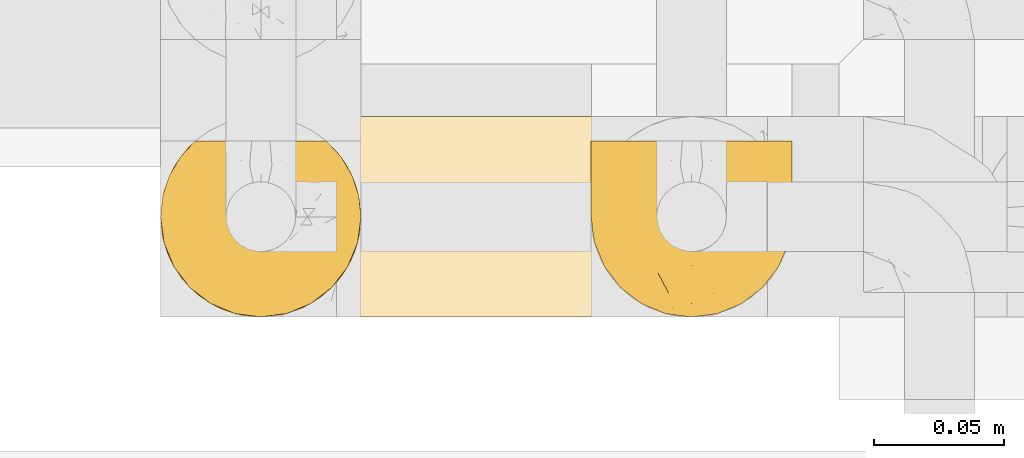
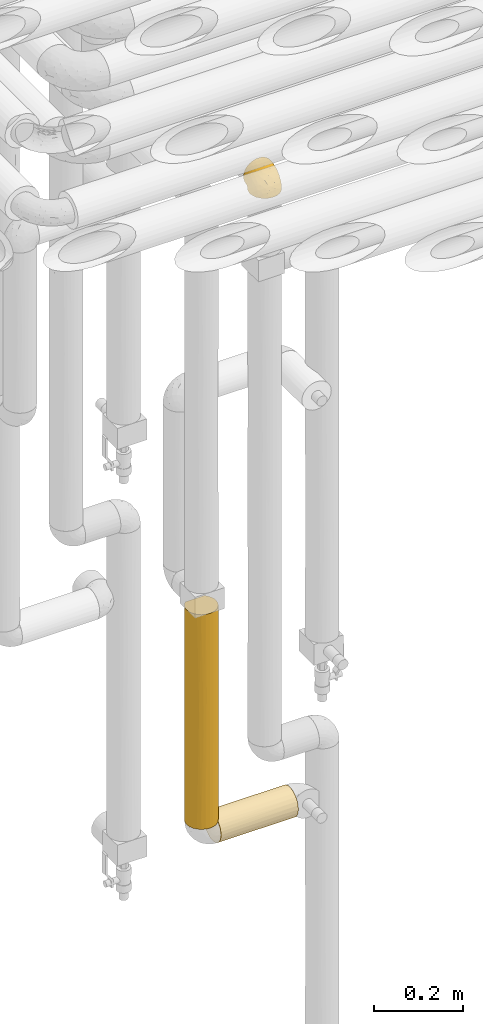
# One storey, part 281 of 827: 3 coverings.
"""IFC2X3 building model written with IfcOpenShell, lengths in millimetres."""

from ifc_helpers import new_model, entity, si_unit, converted_unit, derived_unit, direction, frame, origin, place, context, subcontext, project, spatial, faceted_brep, element, save


model = new_model("IFC2X3")

# Units and contexts
model_context = context("Model", 3, precision=0.01, world=origin(), true_north=direction((6.12303176911189e-17, 1.0)))
body_context = subcontext(model_context, "Body", "Model", "MODEL_VIEW")
ifc_project = project(units=[si_unit("LENGTHUNIT", "METRE", prefix="MILLI"), si_unit("AREAUNIT", "SQUARE_METRE"), si_unit("VOLUMEUNIT", "CUBIC_METRE"), converted_unit("PLANEANGLEUNIT", "DEGREE", entity("IfcRatioMeasure", 0.0174532925199433), si_unit("PLANEANGLEUNIT", "RADIAN"), dimensions=[0, 0, 0, 0, 0, 0, 0]), si_unit("MASSUNIT", "GRAM", prefix="KILO"), derived_unit("MASSDENSITYUNIT", [(si_unit("MASSUNIT", "GRAM", prefix="KILO"), 1), (si_unit("LENGTHUNIT", "METRE"), -3)]), derived_unit("MOMENTOFINERTIAUNIT", [(si_unit("LENGTHUNIT", "METRE"), 4)]), si_unit("TIMEUNIT", "SECOND"), si_unit("FREQUENCYUNIT", "HERTZ"), si_unit("THERMODYNAMICTEMPERATUREUNIT", "DEGREE_CELSIUS"), derived_unit("THERMALTRANSMITTANCEUNIT", [(si_unit("MASSUNIT", "GRAM", prefix="KILO"), 1), (si_unit("THERMODYNAMICTEMPERATUREUNIT", "KELVIN"), -1), (si_unit("TIMEUNIT", "SECOND"), -3)]), derived_unit("VOLUMETRICFLOWRATEUNIT", [(si_unit("LENGTHUNIT", "METRE"), 3), (si_unit("TIMEUNIT", "SECOND"), -1)]), derived_unit("MASSFLOWRATEUNIT", [(si_unit("MASSUNIT", "GRAM", prefix="KILO"), 1), (si_unit("TIMEUNIT", "SECOND"), -1)]), derived_unit("ROTATIONALFREQUENCYUNIT", [(si_unit("TIMEUNIT", "SECOND"), -1)]), si_unit("ELECTRICCURRENTUNIT", "AMPERE"), si_unit("ELECTRICVOLTAGEUNIT", "VOLT"), si_unit("POWERUNIT", "WATT"), si_unit("FORCEUNIT", "NEWTON", prefix="KILO"), si_unit("ILLUMINANCEUNIT", "LUX"), si_unit("LUMINOUSFLUXUNIT", "LUMEN"), si_unit("LUMINOUSINTENSITYUNIT", "CANDELA"), derived_unit("USERDEFINED", [(si_unit("MASSUNIT", "GRAM", prefix="KILO"), -1), (si_unit("LENGTHUNIT", "METRE"), -2), (si_unit("TIMEUNIT", "SECOND"), 3), (si_unit("LUMINOUSFLUXUNIT", "LUMEN"), 1)]), derived_unit("LINEARVELOCITYUNIT", [(si_unit("LENGTHUNIT", "METRE"), 1), (si_unit("TIMEUNIT", "SECOND"), -1)]), si_unit("PRESSUREUNIT", "PASCAL"), derived_unit("USERDEFINED", [(si_unit("LENGTHUNIT", "METRE"), -2), (si_unit("MASSUNIT", "GRAM", prefix="KILO"), 1), (si_unit("TIMEUNIT", "SECOND"), -2)]), derived_unit("LINEARFORCEUNIT", [(si_unit("MASSUNIT", "GRAM", prefix="KILO"), 1), (si_unit("LENGTHUNIT", "METRE"), 1), (si_unit("TIMEUNIT", "SECOND"), -2), (si_unit("LENGTHUNIT", "METRE"), -1)]), derived_unit("PLANARFORCEUNIT", [(si_unit("MASSUNIT", "GRAM", prefix="KILO"), 1), (si_unit("LENGTHUNIT", "METRE"), 1), (si_unit("TIMEUNIT", "SECOND"), -2), (si_unit("LENGTHUNIT", "METRE"), -2)])], contexts=[model_context])

# Site, building, storey
site_placement = place(None, origin())
site = spatial("IfcSite", under=ifc_project, at=site_placement, CompositionType="ELEMENT")
building_placement = place(site_placement, origin())
building = spatial("IfcBuilding", under=site, at=building_placement, CompositionType="ELEMENT")
storey_placement = place(building_placement, frame((0.0, 0.0, 28200.0)))
storey = spatial("IfcBuildingStorey", under=building, at=storey_placement, Name="08", CompositionType="ELEMENT", Elevation=28200.0)

# Coverings
covering_1_placement = place(storey_placement, frame((34952.84, 14884.87, 2769.3)))
element("IfcCovering", 1, at=covering_1_placement, inside=storey, Name=":ADSK_", ObjectType=":ADSK_", PredefinedType="INSULATION", context=body_context, shape_type="Brep", body=[
    faceted_brep([(5.41, 69.15, 47.38), (9.99, 69.15, 54.67), (16.08, 69.15, 60.76), (23.37, 69.15, 65.34), (31.49, 69.15, 68.18), (40.05, 69.15, 69.15), (48.61, 69.15, 68.18), (56.73, 69.15, 65.33), (64.02, 69.15, 60.75), (70.11, 69.15, 54.66), (74.69, 69.15, 47.37), (77.53, 69.15, 39.25), (78.5, 69.15, 30.7), (77.63, 69.15, 22.59), (75.08, 69.15, 14.86), (70.97, 69.15, 7.84), (65.47, 69.15, 1.85), (63.27, 69.15, 1.85), (61.53, 69.15, 1.85), (59.57, 69.15, 1.85), (57.6, 69.15, 1.85), (55.63, 69.15, 1.85), (53.67, 69.15, 1.85), (51.7, 69.15, 1.85), (49.73, 69.15, 1.85), (47.54, 69.15, 1.85), (45.34, 69.15, 1.85), (43.15, 69.15, 1.85), (40.96, 69.15, 1.85), (38.76, 69.15, 1.85), (36.57, 69.15, 1.85), (34.37, 69.15, 1.85), (32.18, 69.15, 1.85), (29.98, 69.15, 1.85), (27.79, 69.15, 1.85), (25.6, 69.15, 1.85), (23.4, 69.15, 1.85), (21.21, 69.15, 1.85), (19.01, 69.15, 1.85), (16.82, 69.15, 1.85), (14.62, 69.15, 1.85), (9.12, 69.15, 7.85), (5.0, 69.15, 14.88), (2.46, 69.15, 22.61), (1.6, 69.15, 30.7), (2.56, 69.15, 39.26), (65.47, 68.89, 1.6), (70.97, 62.89, 1.6), (75.09, 55.87, 1.6), (77.63, 48.14, 1.6), (78.5, 40.05, 1.6), (77.19, 30.09, 1.6), (73.34, 20.82, 1.6), (67.23, 12.86, 1.6), (59.27, 6.75, 1.6), (50.0, 2.91, 1.6), (40.05, 1.6, 1.6), (30.09, 2.91, 1.6), (20.82, 6.75, 1.6), (12.86, 12.86, 1.6), (6.75, 20.82, 1.6), (2.91, 30.09, 1.6), (1.6, 40.05, 1.6), (2.46, 48.14, 1.6), (5.0, 55.87, 1.6), (9.12, 62.89, 1.6), (14.62, 68.89, 1.6), (16.82, 68.89, 1.6), (17.8, 68.89, 1.6), (19.39, 68.89, 1.6), (20.98, 68.89, 1.6), (22.57, 68.89, 1.6), (24.16, 68.89, 1.6), (25.75, 68.89, 1.6), (27.33, 68.89, 1.6), (28.92, 68.89, 1.6), (30.51, 68.89, 1.6), (32.1, 68.89, 1.6), (33.69, 68.89, 1.6), (35.28, 68.89, 1.6), (36.87, 68.89, 1.6), (38.46, 68.89, 1.6), (40.05, 68.89, 1.6), (41.63, 68.89, 1.6), (43.22, 68.89, 1.6), (44.81, 68.89, 1.6), (46.4, 68.89, 1.6), (47.99, 68.89, 1.6), (49.58, 68.89, 1.6), (51.17, 68.89, 1.6), (52.76, 68.89, 1.6), (54.72, 68.89, 1.6), (56.69, 68.89, 1.6), (58.88, 68.89, 1.6), (61.08, 68.89, 1.6), (63.27, 68.89, 1.6), (37.77, 68.97, 1.78), (36.07, 68.96, 1.77), (32.96, 68.97, 1.78), (31.36, 68.97, 1.77), (56.52, 68.98, 1.79), (54.96, 68.97, 1.78), (18.75, 68.96, 1.76), (58.07, 68.96, 1.77), (50.37, 68.96, 1.77), (23.36, 68.96, 1.76), (24.95, 68.96, 1.77), (42.43, 68.96, 1.77), (15.97, 69.0, 1.8), (51.96, 68.96, 1.76), (53.47, 68.96, 1.77), (48.63, 68.97, 1.78), (63.93, 68.96, 1.77), (40.93, 68.96, 1.77), (29.72, 68.96, 1.76), (62.4, 68.97, 1.77), (60.92, 68.97, 1.78), (17.31, 68.97, 1.77), (21.74, 68.96, 1.77), (34.56, 68.96, 1.77), (20.18, 68.97, 1.78), (14.62, 68.97, 1.77), (14.62, 69.02, 1.8), (14.62, 69.08, 1.82), (65.47, 68.97, 1.77), (65.47, 68.94, 1.72), (65.47, 68.92, 1.66), (59.5, 68.96, 1.76), (47.1, 68.96, 1.77), (45.61, 68.95, 1.76), (28.18, 68.96, 1.77), (14.62, 68.92, 1.66), (14.62, 68.94, 1.72), (26.61, 68.98, 1.78), (65.47, 69.08, 1.82), (65.47, 69.02, 1.8), (39.32, 68.96, 1.77), (44.12, 68.97, 1.78), (72.26, 61.33, 3.72), (76.57, 53.1, 7.41), (71.77, 63.33, 6.13), (77.9, 55.53, 19.34), (76.56, 63.33, 17.64), (78.5, 54.6, 26.8), (78.5, 41.99, 8.87), (75.52, 57.07, 9.2), (76.13, 57.95, 12.79), (77.81, 51.56, 14.62), (78.5, 41.58, 7.34), (72.4, 61.7, 5.33), (71.77, 65.0, 7.7), (72.25, 67.02, 9.41), (78.5, 61.87, 28.75), (78.5, 49.27, 21.47), (78.5, 43.94, 16.15), (75.75, 61.21, 14.14), (78.5, 63.4, 29.16), (50.46, 33.11, 57.02), (52.75, 52.82, 64.92), (40.05, 43.3, 64.0), (77.7, 33.73, 11.92), (77.66, 36.52, 19.16), (71.02, 24.87, 28.65), (63.45, 14.17, 24.62), (70.55, 18.43, 15.19), (75.57, 28.67, 18.36), (75.57, 26.0, 9.2), (72.61, 49.25, 46.98), (72.61, 59.72, 50.24), (67.24, 55.1, 56.1), (77.74, 44.72, 28.97), (57.43, 34.15, 54.46), (47.19, 5.25, 21.34), (54.76, 6.75, 18.4), (40.05, 55.54, 66.44), (63.45, 10.47, 12.07), (60.1, 25.49, 45.49), (63.72, 35.53, 50.57), (76.83, 48.22, 36.04), (76.34, 58.71, 42.07), (60.51, 57.42, 62.12), (72.59, 34.84, 37.37), (76.05, 36.87, 29.39), (66.15, 45.01, 53.59), (60.51, 44.4, 58.06), (51.88, 23.96, 49.27), (55.34, 11.2, 29.63), (48.67, 10.56, 33.21), (53.89, 16.81, 40.1), (46.73, 17.38, 44.08), (40.05, 21.38, 49.36), (40.05, 32.34, 56.68), (40.05, 4.3, 15.2), (63.95, 20.65, 35.57), (67.24, 29.66, 41.7), (69.62, 39.6, 46.4), (73.6, 42.55, 41.41), (40.05, 6.74, 27.45), (40.05, 14.06, 38.4), (4.52, 26.84, 12.99), (32.72, 5.28, 21.33), (27.18, 18.52, 42.89), (29.63, 33.13, 57.04), (12.86, 55.1, 56.11), (19.59, 57.43, 62.13), (9.54, 20.72, 21.89), (16.64, 11.46, 16.62), (17.48, 17.69, 32.9), (7.49, 49.26, 46.99), (7.49, 59.73, 50.25), (3.75, 58.71, 42.08), (20.75, 29.72, 49.91), (2.33, 35.35, 15.6), (1.6, 43.94, 16.15), (1.6, 41.99, 8.87), (1.6, 63.4, 29.16), (26.94, 4.93, 13.16), (9.54, 17.46, 10.83), (31.21, 10.94, 33.8), (25.33, 8.92, 25.02), (27.35, 52.83, 64.92), (8.17, 29.34, 32.83), (4.3, 30.26, 20.56), (19.59, 44.4, 58.07), (2.23, 39.06, 21.46), (2.45, 43.06, 28.1), (1.6, 54.6, 26.8), (1.6, 49.27, 21.47), (12.86, 42.69, 51.29), (3.27, 48.2, 36.04), (1.6, 61.87, 28.75), (2.29, 33.44, 8.45), (12.86, 29.67, 41.73), (6.89, 38.5, 39.27), (12.43, 23.35, 33.56), (4.1, 34.97, 27.29), (3.53, 53.1, 7.41), (6.88, 59.68, 3.51), (8.16, 62.19, 4.68), (9.02, 64.11, 5.52), (5.0, 57.97, 8.75), (3.96, 57.95, 12.79), (3.52, 63.33, 17.65), (2.4, 51.77, 13.9), (7.83, 67.02, 9.42), (8.32, 64.98, 7.68), (2.19, 55.53, 19.33), (4.34, 61.22, 14.13)], [[[0, 1, 2, 3, 4, 5, 6, 7, 8, 9, 10, 11, 12, 13, 14, 15, 16, 17, 18, 19, 20, 21, 22, 23, 24, 25, 26, 27, 28, 29, 30, 31, 32, 33, 34, 35, 36, 37, 38, 39, 40, 41, 42, 43, 44, 45]], [[46, 47, 48, 49, 50, 51, 52, 53, 54, 55, 56, 57, 58, 59, 60, 61, 62, 63, 64, 65, 66, 67, 68, 69, 70, 71, 72, 73, 74, 75, 76, 77, 78, 79, 80, 81, 82, 83, 84, 85, 86, 87, 88, 89, 90, 91, 92, 93, 94, 95]], [[96, 97, 30]], [[98, 77, 99]], [[100, 101, 21]], [[69, 68, 102]], [[20, 19, 103]], [[24, 23, 104]], [[20, 103, 100]], [[72, 105, 106]], [[84, 83, 107]], [[89, 88, 104]], [[108, 67, 66]], [[109, 110, 90]], [[111, 25, 24]], [[112, 17, 16]], [[82, 113, 83]], [[109, 23, 22]], [[114, 76, 75]], [[105, 36, 106]], [[104, 111, 24]], [[18, 115, 116]], [[97, 96, 80]], [[67, 108, 117]], [[105, 71, 118]], [[31, 97, 119]], [[102, 120, 69]], [[108, 121, 122, 123, 40]], [[112, 95, 115]], [[17, 115, 18]], [[94, 116, 115]], [[117, 68, 67]], [[38, 117, 39]], [[112, 124, 125, 126, 46]], [[17, 112, 115]], [[70, 120, 118]], [[39, 117, 108]], [[120, 38, 37]], [[120, 37, 118]], [[120, 70, 69]], [[116, 94, 127]], [[128, 86, 129]], [[117, 38, 102]], [[74, 130, 75]], [[99, 33, 32]], [[115, 95, 94]], [[39, 108, 40]], [[108, 66, 131, 132, 121]], [[105, 72, 71]], [[118, 37, 36]], [[71, 70, 118]], [[35, 106, 36]], [[36, 105, 118]], [[35, 133, 106]], [[74, 73, 133]], [[106, 133, 73]], [[99, 114, 33]], [[133, 35, 34]], [[73, 72, 106]], [[95, 112, 46]], [[112, 16, 134, 135, 124]], [[130, 114, 75]], [[99, 76, 114]], [[114, 130, 33]], [[34, 33, 130]], [[78, 77, 98]], [[98, 119, 78]], [[130, 133, 34]], [[133, 130, 74]], [[79, 97, 80]], [[98, 99, 32]], [[98, 32, 31]], [[77, 76, 99]], [[97, 79, 119]], [[136, 96, 29]], [[30, 97, 31]], [[136, 29, 28]], [[81, 80, 96]], [[29, 96, 30]], [[31, 119, 98]], [[119, 79, 78]], [[96, 136, 81]], [[82, 81, 136]], [[113, 107, 83]], [[84, 107, 137]], [[107, 27, 137]], [[113, 28, 107]], [[27, 107, 28]], [[85, 84, 137]], [[137, 27, 26]], [[113, 136, 28]], [[136, 113, 82]], [[109, 89, 104]], [[86, 85, 129]], [[89, 109, 90]], [[111, 87, 128]], [[26, 129, 137]], [[88, 111, 104]], [[25, 111, 128]], [[22, 110, 109]], [[23, 109, 104]], [[110, 91, 90]], [[100, 92, 101]], [[110, 22, 101]], [[91, 110, 101]], [[116, 19, 18]], [[111, 88, 87]], [[127, 103, 19]], [[25, 128, 26]], [[86, 128, 87]], [[128, 129, 26]], [[137, 129, 85]], [[120, 102, 38]], [[117, 102, 68]], [[91, 101, 92]], [[21, 101, 22]], [[93, 92, 103]], [[100, 21, 20]], [[100, 103, 92]], [[127, 93, 103]], [[93, 127, 94]], [[116, 127, 19]], [[126, 138, 47]], [[48, 138, 139]], [[140, 125, 124]], [[141, 142, 143]], [[144, 49, 139]], [[145, 140, 146]], [[48, 139, 49]], [[139, 145, 147]], [[49, 144, 148, 50]], [[126, 125, 149]], [[14, 13, 142]], [[150, 146, 140]], [[149, 140, 145]], [[151, 150, 135]], [[151, 14, 142]], [[16, 15, 134]], [[13, 152, 142]], [[124, 150, 140]], [[141, 143, 153]], [[14, 151, 15]], [[15, 151, 134]], [[47, 46, 126]], [[139, 154, 144]], [[138, 48, 47]], [[125, 140, 149]], [[135, 134, 151]], [[146, 155, 141]], [[145, 146, 147]], [[149, 139, 138]], [[147, 153, 154]], [[147, 146, 141]], [[139, 147, 154]], [[139, 149, 145]], [[149, 138, 126]], [[147, 141, 153]], [[146, 150, 155]], [[151, 155, 150]], [[142, 141, 155]], [[13, 12, 156, 152]], [[152, 143, 142]], [[151, 142, 155]], [[150, 124, 135]], [[157, 158, 159]], [[160, 154, 161]], [[162, 163, 164]], [[165, 166, 160]], [[167, 168, 169]], [[153, 170, 161]], [[156, 12, 11]], [[158, 157, 171]], [[172, 55, 173]], [[158, 6, 174]], [[175, 54, 53]], [[52, 166, 164]], [[52, 164, 53]], [[54, 175, 173]], [[166, 52, 51]], [[176, 177, 171]], [[178, 143, 179]], [[156, 11, 179]], [[8, 7, 180]], [[169, 9, 8]], [[179, 143, 152, 156]], [[179, 11, 10]], [[168, 179, 10]], [[181, 162, 182]], [[179, 167, 178]], [[183, 184, 177]], [[183, 169, 184]], [[176, 171, 185]], [[172, 186, 187]], [[158, 7, 6]], [[159, 158, 174]], [[184, 180, 158]], [[54, 173, 55]], [[180, 169, 8]], [[188, 189, 187]], [[9, 168, 10]], [[186, 188, 187]], [[190, 157, 159, 191]], [[55, 172, 192]], [[176, 193, 194]], [[161, 170, 182]], [[162, 164, 165]], [[175, 164, 163]], [[51, 50, 148]], [[167, 195, 196]], [[178, 182, 170]], [[6, 5, 174]], [[158, 180, 7]], [[169, 180, 184]], [[169, 168, 9]], [[179, 168, 167]], [[182, 162, 165]], [[162, 194, 193]], [[161, 165, 160]], [[195, 181, 196]], [[192, 172, 197]], [[192, 56, 55]], [[189, 190, 198]], [[198, 197, 187]], [[172, 187, 197]], [[185, 189, 188]], [[198, 187, 189]], [[186, 172, 173]], [[173, 163, 186]], [[193, 186, 163]], [[176, 185, 188]], [[185, 157, 190]], [[188, 186, 193]], [[177, 176, 194]], [[188, 193, 176]], [[162, 193, 163]], [[195, 177, 194]], [[171, 177, 184]], [[181, 195, 194]], [[183, 167, 169]], [[162, 181, 194]], [[196, 182, 178]], [[158, 171, 184]], [[171, 157, 185]], [[177, 195, 183]], [[167, 183, 195]], [[182, 196, 181]], [[178, 170, 143]], [[178, 167, 196]], [[164, 175, 53]], [[173, 175, 163]], [[160, 51, 148]], [[164, 166, 165]], [[51, 160, 166]], [[160, 148, 144, 154]], [[153, 161, 154]], [[182, 165, 161]], [[190, 189, 185]], [[143, 170, 153]], [[60, 199, 61]], [[197, 200, 192]], [[201, 190, 202]], [[200, 57, 192]], [[203, 204, 2]], [[205, 206, 207]], [[208, 209, 210]], [[211, 207, 201]], [[212, 213, 214]], [[45, 215, 210]], [[216, 206, 58]], [[45, 44, 215]], [[59, 217, 60]], [[60, 217, 199]], [[0, 45, 210]], [[218, 201, 219]], [[202, 159, 220]], [[205, 221, 222]], [[223, 204, 203]], [[1, 203, 2]], [[57, 200, 216]], [[220, 3, 204]], [[220, 174, 4]], [[1, 0, 209]], [[212, 224, 213]], [[225, 226, 227]], [[228, 223, 203]], [[208, 210, 229]], [[210, 226, 229]], [[3, 220, 4]], [[58, 206, 59]], [[209, 203, 1]], [[202, 220, 223]], [[228, 203, 208]], [[202, 211, 201]], [[3, 2, 204]], [[202, 190, 191, 159]], [[210, 215, 230, 226]], [[199, 212, 231]], [[232, 233, 221]], [[233, 208, 229]], [[207, 206, 219]], [[217, 206, 205]], [[227, 224, 225]], [[233, 232, 228]], [[201, 207, 219]], [[234, 232, 221]], [[218, 219, 200]], [[202, 223, 211]], [[174, 220, 159]], [[174, 5, 4]], [[61, 231, 62]], [[220, 204, 223]], [[210, 209, 0]], [[203, 209, 208]], [[225, 233, 229]], [[224, 227, 213]], [[221, 233, 235]], [[57, 56, 192]], [[198, 218, 197]], [[200, 219, 216]], [[201, 198, 190]], [[197, 218, 200]], [[198, 201, 218]], [[206, 216, 219]], [[58, 57, 216]], [[231, 212, 214]], [[222, 212, 199]], [[228, 211, 223]], [[207, 211, 232]], [[62, 231, 214]], [[199, 231, 61]], [[233, 228, 208]], [[211, 228, 232]], [[222, 221, 235]], [[234, 205, 207]], [[206, 217, 59]], [[199, 217, 205]], [[205, 222, 199]], [[224, 222, 235]], [[222, 224, 212]], [[224, 235, 225]], [[233, 225, 235]], [[226, 225, 229]], [[205, 234, 221]], [[207, 232, 234]], [[63, 214, 236]], [[214, 213, 236]], [[214, 63, 62]], [[237, 236, 238]], [[238, 132, 131]], [[236, 237, 64]], [[239, 240, 241]], [[63, 236, 64]], [[131, 66, 65]], [[237, 131, 65]], [[242, 230, 43]], [[237, 65, 64]], [[239, 121, 132]], [[42, 242, 43]], [[241, 240, 243]], [[41, 123, 244]], [[43, 230, 215, 44]], [[244, 122, 245]], [[227, 246, 243]], [[241, 247, 245]], [[121, 239, 245]], [[41, 40, 123]], [[132, 238, 239]], [[244, 42, 41]], [[131, 237, 238]], [[240, 239, 238]], [[245, 239, 241]], [[247, 241, 246]], [[247, 244, 245]], [[238, 236, 240]], [[243, 236, 213]], [[236, 243, 240]], [[227, 226, 246]], [[243, 213, 227]], [[242, 246, 226]], [[243, 246, 241]], [[246, 242, 247]], [[244, 247, 242]], [[242, 226, 230]], [[42, 244, 242]], [[122, 244, 123]], [[122, 121, 245]]]),
])
covering_2_placement = place(storey_placement, frame((34787.85, 14884.92, 1087.5)))
element("IfcCovering", 2, at=covering_2_placement, inside=storey, Name=":ADSK_", ObjectType=":ADSK_", PredefinedType="INSULATION", context=body_context, shape_type="Brep", body=[
    faceted_brep([(73.25, 20.8, 593.5), (77.09, 30.06, 593.5), (78.4, 40.0, 593.5), (77.52, 48.16, 593.5), (74.93, 55.94, 593.5), (70.75, 62.99, 593.5), (65.17, 69.0, 593.5), (14.82, 69.0, 593.5), (9.24, 62.99, 593.5), (5.06, 55.94, 593.5), (2.47, 48.16, 593.5), (1.6, 40.0, 593.5), (2.9, 30.06, 593.5), (6.74, 20.8, 593.5), (12.84, 12.84, 593.5), (20.8, 6.74, 593.5), (30.06, 2.9, 593.5), (40.0, 1.6, 593.5), (49.93, 2.9, 593.5), (59.2, 6.74, 593.5), (67.15, 12.84, 593.5), (69.1, 14.94, 1.6), (63.08, 9.31, 1.6), (56.01, 5.09, 1.6), (48.2, 2.48, 1.6), (40.0, 1.6, 1.6), (30.06, 2.9, 1.6), (20.8, 6.74, 1.6), (12.84, 12.84, 1.6), (6.74, 20.8, 1.6), (2.9, 30.06, 1.6), (1.6, 40.0, 1.6), (2.9, 49.93, 1.6), (6.74, 59.2, 1.6), (12.84, 67.15, 1.6), (20.8, 73.25, 1.6), (30.06, 77.09, 1.6), (40.0, 78.4, 1.6), (48.2, 77.51, 1.6), (56.01, 74.9, 1.6), (63.08, 70.68, 1.6), (69.1, 65.05, 1.6), (77.79, 46.78, 10.29), (76.0, 53.36, 8.5), (77.01, 50.2, 296.29), (74.59, 56.67, 378.86), (73.07, 59.51, 5.57), (71.09, 62.53, 290.54), (50.25, 77.0, 298.79), (53.43, 75.97, 586.52), (56.68, 74.58, 392.52), (78.4, 40.0, 302.2), (78.4, 40.0, 227.27), (78.4, 40.0, 10.9), (62.64, 71.01, 304.65), (57.7, 74.07, 194.68), (40.0, 78.4, 292.85), (46.82, 77.78, 584.71), (59.61, 73.01, 589.48), (40.0, 78.4, 367.72), (40.0, 78.4, 584.1), (29.74, 77.0, 301.9), (11.64, 65.89, 381.54), (17.34, 71.0, 292.9), (23.33, 74.59, 205.22), (6.96, 59.58, 309.24), (33.17, 77.78, 584.71), (26.56, 75.97, 586.52), (20.38, 73.01, 589.48), (2.89, 49.87, 299.72), (1.6, 40.0, 377.12), (2.35, 32.42, 385.18), (4.52, 25.3, 339.18), (32.5, 2.33, 374.62), (25.3, 4.52, 297.55), (9.53, 16.62, 297.55), (16.62, 9.53, 339.18), (40.0, 1.6, 297.55), (40.0, 1.6, 217.97), (49.87, 2.89, 295.47), (59.66, 7.01, 285.81), (65.97, 11.72, 213.92), (71.08, 17.45, 301.5), (74.63, 23.42, 391.28), (73.07, 20.48, 5.57), (76.0, 26.63, 8.5), (77.02, 29.79, 293.21), (77.79, 33.21, 10.29)], [[[0, 1, 2, 3, 4, 5, 6, 7, 8, 9, 10, 11, 12, 13, 14, 15, 16, 17, 18, 19, 20]], [[21, 22, 23, 24, 25, 26, 27, 28, 29, 30, 31, 32, 33, 34, 35, 36, 37, 38, 39, 40, 41]], [[42, 43, 44]], [[5, 4, 45]], [[46, 41, 47]], [[48, 49, 50]], [[43, 45, 44]], [[45, 43, 46]], [[3, 51, 44]], [[51, 42, 44]], [[3, 44, 45]], [[42, 51, 52, 53]], [[47, 54, 6]], [[3, 45, 4]], [[51, 3, 2]], [[6, 5, 47]], [[55, 48, 50]], [[56, 38, 37]], [[39, 38, 48]], [[40, 55, 54]], [[48, 55, 39]], [[48, 56, 57]], [[55, 40, 39]], [[58, 6, 54]], [[46, 47, 45]], [[57, 49, 48]], [[38, 56, 48]], [[41, 40, 54]], [[50, 58, 54]], [[58, 50, 49]], [[55, 50, 54]], [[41, 54, 47]], [[57, 56, 59, 60]], [[5, 45, 47]], [[61, 59, 56, 37]], [[61, 37, 36]], [[34, 62, 63]], [[35, 63, 64]], [[34, 65, 62]], [[66, 61, 67]], [[66, 60, 59]], [[64, 67, 61]], [[59, 61, 66]], [[35, 34, 63]], [[63, 7, 68]], [[64, 68, 67]], [[34, 33, 65]], [[36, 64, 61]], [[69, 32, 31]], [[33, 69, 65]], [[68, 64, 63]], [[70, 11, 10]], [[9, 65, 69]], [[8, 65, 9]], [[69, 33, 32]], [[65, 8, 62]], [[70, 10, 69]], [[70, 69, 31]], [[9, 69, 10]], [[7, 63, 62]], [[7, 62, 8]], [[36, 35, 64]], [[71, 30, 72]], [[26, 73, 74]], [[71, 11, 70, 31]], [[72, 75, 13]], [[75, 72, 29]], [[71, 31, 30]], [[28, 75, 29]], [[75, 14, 13]], [[13, 12, 72]], [[27, 74, 76]], [[17, 73, 77]], [[74, 27, 26]], [[74, 15, 76]], [[28, 76, 75]], [[26, 25, 78, 77]], [[14, 75, 76]], [[27, 76, 28]], [[71, 72, 12]], [[15, 14, 76]], [[74, 73, 16]], [[15, 74, 16]], [[29, 72, 30]], [[77, 73, 26]], [[11, 71, 12]], [[73, 17, 16]], [[78, 24, 79]], [[80, 22, 81]], [[21, 81, 22]], [[20, 81, 82]], [[80, 23, 22]], [[83, 84, 85]], [[24, 78, 25]], [[23, 80, 79]], [[17, 79, 18]], [[20, 19, 80]], [[1, 0, 83]], [[82, 81, 21]], [[83, 85, 86]], [[20, 80, 81]], [[87, 86, 85]], [[0, 20, 82]], [[87, 53, 52]], [[52, 86, 87]], [[79, 19, 18]], [[83, 0, 82]], [[19, 79, 80]], [[2, 1, 86]], [[86, 52, 51, 2]], [[23, 79, 24]], [[84, 83, 82]], [[84, 82, 21]], [[1, 83, 86]], [[79, 17, 77, 78]], [[49, 57, 60, 66, 67, 68, 7, 6, 58]], [[41, 46, 43, 42, 53, 87, 85, 84, 21]]]),
])
covering_3_placement = place(storey_placement, frame((34855.35, 14884.92, 1020.0)))
element("IfcCovering", 3, at=covering_3_placement, inside=storey, Name=":ADSK_", ObjectType=":ADSK_", PredefinedType="INSULATION", context=body_context, shape_type="Brep", body=[
    faceted_brep([(1.6, 20.8, 6.74), (1.6, 12.84, 12.84), (1.6, 6.74, 20.8), (1.6, 2.9, 30.06), (1.6, 1.6, 40.0), (1.6, 2.48, 48.2), (1.6, 5.09, 56.01), (1.6, 9.31, 63.08), (1.6, 14.94, 69.1), (1.6, 65.05, 69.1), (1.6, 70.68, 63.08), (1.6, 74.9, 56.01), (1.6, 77.51, 48.2), (1.6, 78.4, 40.0), (1.6, 77.09, 30.06), (1.6, 73.25, 20.8), (1.6, 67.15, 12.84), (1.6, 59.2, 6.74), (1.6, 49.93, 2.9), (1.6, 40.0, 1.6), (1.6, 30.06, 2.9), (203.4, 20.8, 6.74), (203.4, 30.06, 2.9), (203.4, 40.0, 1.6), (203.4, 49.93, 2.9), (203.4, 59.2, 6.74), (203.4, 67.15, 12.84), (203.4, 73.25, 20.8), (203.4, 77.09, 30.06), (203.4, 78.4, 40.0), (203.4, 77.09, 49.93), (203.4, 73.25, 59.2), (203.4, 67.15, 67.15), (203.4, 59.2, 73.25), (203.4, 49.93, 77.09), (203.4, 40.0, 78.4), (203.4, 30.06, 77.09), (203.4, 20.8, 73.25), (203.4, 12.84, 67.15), (203.4, 6.74, 59.2), (203.4, 2.9, 49.93), (203.4, 1.6, 40.0), (203.4, 2.9, 30.06), (203.4, 6.74, 20.8), (203.4, 12.84, 12.84), (8.5, 26.63, 76.0), (10.29, 33.21, 77.79), (10.9, 40.0, 78.4), (5.57, 20.48, 73.07), (10.29, 46.78, 77.79), (8.5, 53.36, 76.0), (5.57, 59.51, 73.07)], [[[0, 1, 2, 3, 4, 5, 6, 7, 8, 9, 10, 11, 12, 13, 14, 15, 16, 17, 18, 19, 20]], [[21, 22, 23, 24, 25, 26, 27, 28, 29, 30, 31, 32, 33, 34, 35, 36, 37, 38, 39, 40, 41, 42, 43, 44]], [[28, 27, 15, 14]], [[29, 28, 14, 13]], [[27, 26, 16, 15]], [[18, 17, 25, 24]], [[19, 18, 24, 23]], [[26, 25, 17, 16]], [[20, 19, 23, 22]], [[0, 20, 22, 21]], [[21, 44, 1, 0]], [[3, 2, 43, 42]], [[4, 3, 42, 41]], [[44, 43, 2, 1]], [[5, 41, 40]], [[6, 40, 39]], [[7, 39, 38]], [[4, 41, 5]], [[5, 40, 6]], [[39, 7, 6]], [[38, 8, 7]], [[45, 37, 36]], [[36, 35, 46]], [[47, 46, 35]], [[48, 8, 37]], [[46, 45, 36]], [[48, 37, 45]], [[37, 8, 38]], [[49, 47, 35]], [[49, 35, 34]], [[50, 34, 33]], [[50, 49, 34]], [[9, 51, 33]], [[50, 33, 51]], [[33, 32, 9]], [[10, 32, 31]], [[11, 31, 30]], [[12, 30, 29]], [[10, 31, 11]], [[11, 30, 12]], [[29, 13, 12]], [[32, 10, 9]], [[8, 48, 45, 46, 47, 49, 50, 51, 9]]]),
])

save(model, "model.ifc")
